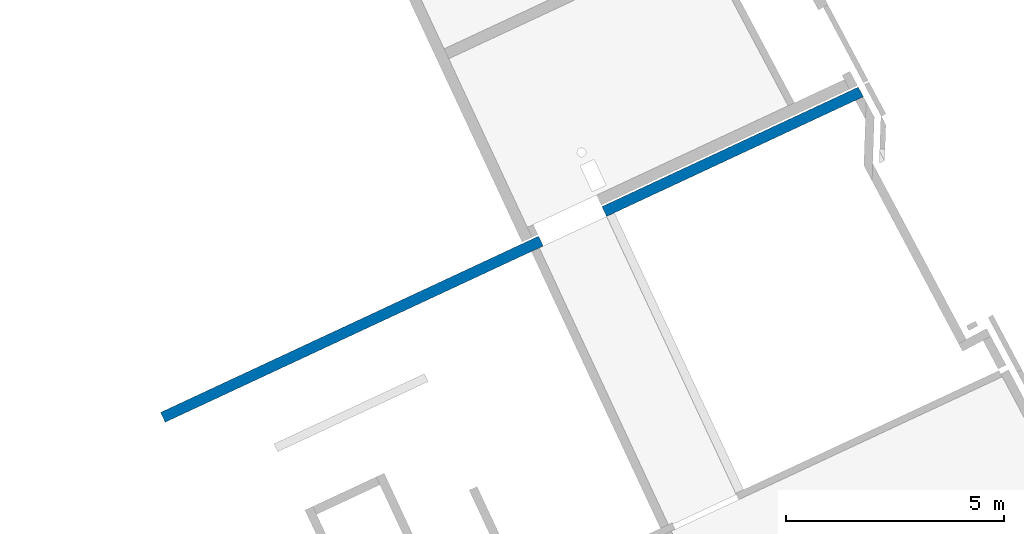
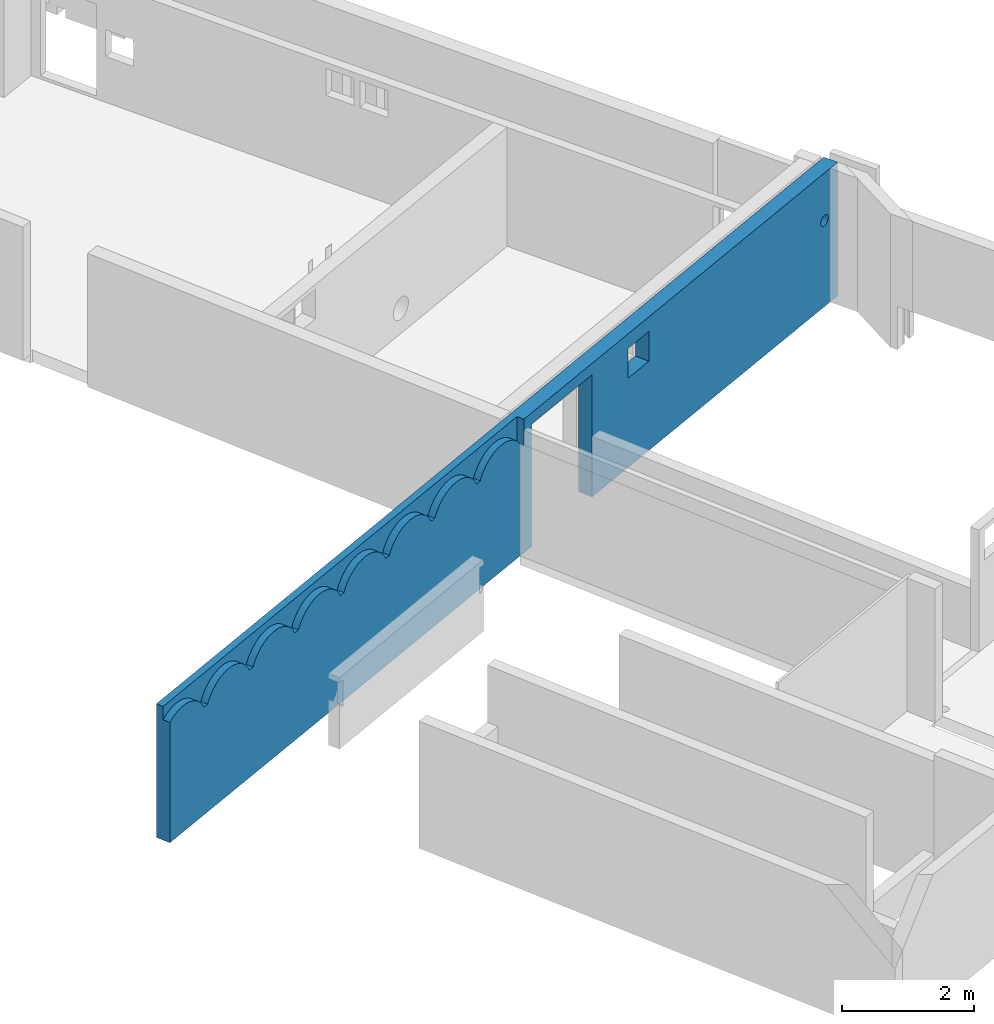
# One storey, part 9 of 13: 1 wall.
"""IFC2X3 building model written with IfcOpenShell, lengths in metres."""

import ifcopenshell
import ifcopenshell.guid

model = None  # the IFC model being written
_history = None  # IfcOwnerHistory: only IFC2X3 demands one
_inside = {}  # id of a spatial element -> (the spatial element, [elements in it])
_under = {}  # id of a project, library or spatial element -> (it, [spatial elements below it])
_declared = {}  # id of a project -> (the project, [libraries it declares])
_typed = {}  # id of a type object -> (the type object, [elements of that type])
_made_of = {}  # id of a material, layer set ... -> (it, [elements and type objects made of it])


def new_model(schema):
    """Start an empty IFC model of exactly this schema.

    Asked for "IFC4X3", IfcOpenShell would pick the latest addendum, in which some entities
    have other attributes; the version numbers below select the first issue.
    IFC2X3 requires an IfcOwnerHistory on every rooted entity: one is made here for all.
    """
    global model, _history
    if schema == "IFC4X3":
        model = ifcopenshell.file(schema_version=(4, 3, 0, 0))
    else:
        model = ifcopenshell.file(schema=schema)
    _inside.clear()
    _under.clear()
    _declared.clear()
    _typed.clear()
    _made_of.clear()
    _history = None
    if model.schema == "IFC2X3":
        org = make("IfcOrganization", Name="unknown")
        user = make(
            "IfcPersonAndOrganization",
            ThePerson=make("IfcPerson", FamilyName="unknown"),
            TheOrganization=org,
        )
        app = make(
            "IfcApplication",
            ApplicationDeveloper=org,
            Version="unknown",
            ApplicationFullName="unknown",
            ApplicationIdentifier="unknown",
        )
        _history = make(
            "IfcOwnerHistory",
            OwningUser=user,
            OwningApplication=app,
            ChangeAction="ADDED",
            CreationDate=0,
        )
    return model


def make(cls, **values):
    """One entity of the class cls with the attributes given. An attribute that is None is left unset."""
    return model.create_entity(
        cls, **{name: value for name, value in values.items() if value is not None}
    )


def entity(cls, *values):
    """Any entity or typed value of the class cls, its attributes in the order of the schema. None: left unset."""
    e = model.create_entity(cls)
    for i, value in enumerate(values):
        if value is not None:
            e[i] = value
    return e


def rooted(cls, **values):
    """An entity with a GlobalId (a new one), such as an element, a storey or a relation."""
    return make(cls, GlobalId=ifcopenshell.guid.new(), OwnerHistory=_history, **values)


def si_unit(unit_type, name, prefix=None):
    """IfcSIUnit, for example si_unit("LENGTHUNIT", "METRE", prefix="MILLI")."""
    return make("IfcSIUnit", UnitType=unit_type, Prefix=prefix, Name=name)


def converted_unit(unit_type, name, factor, base, dimensions=None, offset=None):
    """IfcConversionBasedUnit, such as the inch: factor (a typed value) times the base unit."""
    return make(
        "IfcConversionBasedUnit"
        if offset is None
        else "IfcConversionBasedUnitWithOffset",
        ConversionOffset=offset,
        Dimensions=None
        if dimensions is None
        else entity("IfcDimensionalExponents", *dimensions),
        UnitType=unit_type,
        Name=name,
        ConversionFactor=make(
            "IfcMeasureWithUnit", ValueComponent=factor, UnitComponent=base
        ),
    )


def derived_unit(unit_type, elements):
    """IfcDerivedUnit: a product of units, each with its exponent."""
    return make(
        "IfcDerivedUnit",
        Elements=[
            make("IfcDerivedUnitElement", Unit=unit, Exponent=power)
            for unit, power in elements
        ],
        UnitType=unit_type,
    )


def assignment(units):
    """IfcUnitAssignment: the units of a project."""
    return None if units is None else make("IfcUnitAssignment", Units=units)


def point(xyz):
    """IfcCartesianPoint."""
    return None if xyz is None else make("IfcCartesianPoint", Coordinates=xyz)


def direction(xyz):
    """IfcDirection."""
    return None if xyz is None else make("IfcDirection", DirectionRatios=xyz)


def frame(location, z_axis=None, x_axis=None):
    """IfcAxis2Placement3D, a coordinate frame: its origin and axes. An axis left out is left unset."""
    return make(
        "IfcAxis2Placement3D",
        Location=point(location),
        Axis=direction(z_axis),
        RefDirection=direction(x_axis),
    )


def origin():
    """The frame at (0, 0, 0) with its axes left unset."""
    return frame((0.0, 0.0, 0.0))


def place(relative_to, where):
    """IfcLocalPlacement: puts the frame where relative to a parent placement (None: the world)."""
    return make(
        "IfcLocalPlacement", PlacementRelTo=relative_to, RelativePlacement=where
    )


def context(
    kind, dimensions, precision=None, world=None, true_north=None, identifier=None
):
    """IfcGeometricRepresentationContext, for example the 3D "Model" context."""
    return make(
        "IfcGeometricRepresentationContext",
        ContextIdentifier=identifier,
        ContextType=kind,
        CoordinateSpaceDimension=dimensions,
        Precision=precision,
        WorldCoordinateSystem=world,
        TrueNorth=true_north,
    )


def subcontext(parent, identifier, kind, view, scale=None):
    """IfcGeometricRepresentationSubContext, for example "Body" below "Model"."""
    return make(
        "IfcGeometricRepresentationSubContext",
        ContextIdentifier=identifier,
        ContextType=kind,
        ParentContext=parent,
        TargetScale=scale,
        TargetView=view,
    )


def project(units=None, contexts=None):
    """IfcProject with its units and contexts."""
    return rooted(
        "IfcProject",
        Name="project",
        RepresentationContexts=contexts,
        UnitsInContext=assignment(units),
    )


def spatial(cls, under=None, at=None, **own):
    """A site, building, storey or space (cls), placed at a placement, below another one or the project."""
    s = rooted(cls, ObjectPlacement=at, **own)
    if under is not None:
        _under.setdefault(under.id(), (under, []))[1].append(s)
    return s


def faces_of(points, faces, orient=None, outer=None):
    """IfcFace entities. A face is a list of loops; a loop is a list of indices into points, from 0.

    orient and outer hold one flag for each loop. By default every Orientation is true, the
    first loop of a face is its IfcFaceOuterBound and the others are IfcFaceBound.
    """
    made = []
    for i, loops in enumerate(faces):
        bounds = []
        for j, loop in enumerate(loops):
            is_outer = j == 0 if outer is None else outer[i][j]
            bounds.append(
                make(
                    "IfcFaceOuterBound" if is_outer else "IfcFaceBound",
                    Bound=make("IfcPolyLoop", Polygon=[points[k] for k in loop]),
                    Orientation=True if orient is None else orient[i][j],
                )
            )
        made.append(make("IfcFace", Bounds=bounds))
    return made


def faceted_brep(points, faces, orient=None, outer=None, voids=None):
    """IfcFacetedBrep: a solid bounded by flat faces; with voids (closed shells), ...WithVoids."""
    shared = [point(p) for p in points]
    hull = make("IfcClosedShell", CfsFaces=faces_of(shared, faces, orient, outer))
    if voids is None:
        return make("IfcFacetedBrep", Outer=hull)
    return make(
        "IfcFacetedBrepWithVoids",
        Outer=hull,
        Voids=[
            make(cls, CfsFaces=faces_of(shared, fs, o, b)) for cls, fs, o, b in voids
        ],
    )


def shape(context_of_items, identifier, shape_type, items):
    """IfcShapeRepresentation: the items that make up one representation, for example the "Body"."""
    return make(
        "IfcShapeRepresentation",
        ContextOfItems=context_of_items,
        RepresentationIdentifier=identifier,
        RepresentationType=shape_type,
        Items=items,
    )


def material(Name=None, Category=None):
    """IfcMaterial."""
    return make("IfcMaterial", Name=Name, Category=Category)


def layer(
    of_material, thickness, ventilated=None, Name=None, Category=None, Priority=None
):
    """IfcMaterialLayer: one layer of a wall or slab, of a material (None: an air gap)."""
    return make(
        "IfcMaterialLayer",
        Material=of_material,
        LayerThickness=thickness,
        IsVentilated=ventilated,
        Name=Name,
        Category=Category,
        Priority=Priority,
    )


def layer_set(layers, Name=None):
    """IfcMaterialLayerSet."""
    return make("IfcMaterialLayerSet", MaterialLayers=layers, LayerSetName=Name)


def made_of(thing, what):
    """Note that an element or type object is made of a material, layer set ...; save() writes the relation."""
    if what is not None:
        _made_of.setdefault(what.id(), (what, []))[1].append(thing)
    return thing


def type_object(cls, material=None, **own):
    """A type object (cls), such as IfcWallType, which elements share."""
    return made_of(rooted(cls, **own), material)


def element(
    cls,
    number,
    at=None,
    inside=None,
    cuts=None,
    type_object=None,
    material=None,
    context=None,
    identifier="Body",
    shape_type=None,
    held_by="IfcProductDefinitionShape",
    body=None,
    shapes=None,
    **own,
):
    """One element of the class cls, such as IfcWall. Its Tag is "e" and its number.

    at: its placement. inside: the storey or other place that contains it. cuts: it is an
    opening in that element (IfcRelVoidsElement). A single representation is given by context,
    identifier, shape_type and body (its items); several are given by shapes. held_by: the class
    of the entity that holds the representations. save() writes the other relations.
    """
    e = rooted(cls, Tag="e%d" % number, ObjectPlacement=at, **own)
    if body is not None:
        shapes = [shape(context, identifier, shape_type, body)]
    if shapes is not None:
        e.Representation = make(held_by, Representations=shapes)
    if inside is not None:
        _inside.setdefault(inside.id(), (inside, []))[1].append(e)
    if cuts is not None:
        rooted(
            "IfcRelVoidsElement", RelatingBuildingElement=cuts, RelatedOpeningElement=e
        )
    if type_object is not None:
        _typed.setdefault(type_object.id(), (type_object, []))[1].append(e)
    return made_of(e, material)


def aggregate(whole, parts):
    """IfcRelAggregates: a whole, such as a stair, and the parts it consists of."""
    return rooted("IfcRelAggregates", RelatingObject=whole, RelatedObjects=parts)


def save(model, path):
    """Write the relations noted so far, then the file.

    IfcRelAggregates (storeys below a building ...), IfcRelContainedInSpatialStructure (elements
    in a storey), IfcRelDefinesByType, IfcRelAssociatesMaterial and IfcRelDeclares: one each for
    every whole, place, type object, material and project.
    """
    for whole, parts in _under.values():
        aggregate(whole, parts)
    for where, things in _inside.values():
        rooted(
            "IfcRelContainedInSpatialStructure",
            RelatedElements=things,
            RelatingStructure=where,
        )
    for kind, things in _typed.values():
        rooted("IfcRelDefinesByType", RelatedObjects=things, RelatingType=kind)
    for what, things in _made_of.values():
        rooted("IfcRelAssociatesMaterial", RelatedObjects=things, RelatingMaterial=what)
    for by, libraries in _declared.values():
        rooted("IfcRelDeclares", RelatingContext=by, RelatedDefinitions=libraries)
    model.write(path)


model = new_model("IFC2X3")

# Units and contexts
model_context = context("Model", 3, precision=1e-05, world=origin(), true_north=direction((6.12303176911189e-17, 1.0)))
body_context = subcontext(model_context, "Body", "Model", "MODEL_VIEW")
ifc_project = project(units=[si_unit("LENGTHUNIT", "METRE"), si_unit("AREAUNIT", "SQUARE_METRE"), si_unit("VOLUMEUNIT", "CUBIC_METRE"), converted_unit("PLANEANGLEUNIT", "DEGREE", entity("IfcRatioMeasure", 0.0174532925199433), si_unit("PLANEANGLEUNIT", "RADIAN"), dimensions=[0, 0, 0, 0, 0, 0, 0]), si_unit("MASSUNIT", "GRAM", prefix="KILO"), derived_unit("MASSDENSITYUNIT", [(si_unit("MASSUNIT", "GRAM", prefix="KILO"), 1), (si_unit("LENGTHUNIT", "METRE"), -3)]), si_unit("TIMEUNIT", "SECOND"), si_unit("FREQUENCYUNIT", "HERTZ"), si_unit("THERMODYNAMICTEMPERATUREUNIT", "DEGREE_CELSIUS"), derived_unit("THERMALTRANSMITTANCEUNIT", [(si_unit("MASSUNIT", "GRAM", prefix="KILO"), 1), (si_unit("THERMODYNAMICTEMPERATUREUNIT", "KELVIN"), -1), (si_unit("TIMEUNIT", "SECOND"), -3)]), derived_unit("VOLUMETRICFLOWRATEUNIT", [(si_unit("LENGTHUNIT", "METRE"), 3), (si_unit("TIMEUNIT", "SECOND"), -1)]), si_unit("ELECTRICCURRENTUNIT", "AMPERE"), si_unit("ELECTRICVOLTAGEUNIT", "VOLT"), si_unit("POWERUNIT", "WATT"), si_unit("FORCEUNIT", "NEWTON", prefix="KILO"), si_unit("ILLUMINANCEUNIT", "LUX"), si_unit("LUMINOUSFLUXUNIT", "LUMEN"), si_unit("LUMINOUSINTENSITYUNIT", "CANDELA"), derived_unit("USERDEFINED", [(si_unit("MASSUNIT", "GRAM", prefix="KILO"), -1), (si_unit("LENGTHUNIT", "METRE"), -2), (si_unit("TIMEUNIT", "SECOND"), 3), (si_unit("LUMINOUSFLUXUNIT", "LUMEN"), 1)]), derived_unit("LINEARVELOCITYUNIT", [(si_unit("LENGTHUNIT", "METRE"), 1), (si_unit("TIMEUNIT", "SECOND"), -1)]), si_unit("PRESSUREUNIT", "PASCAL"), derived_unit("USERDEFINED", [(si_unit("LENGTHUNIT", "METRE"), -2), (si_unit("MASSUNIT", "GRAM", prefix="KILO"), 1), (si_unit("TIMEUNIT", "SECOND"), -2)])], contexts=[model_context])

# Site, building, storey
site_placement = place(None, frame((5.36960000000003, 43.3158000000006, 0.0), z_axis=(0.0, 0.0, 1.0), x_axis=(-0.422618261740703, 0.906307787036648, 0.0)))
site = spatial("IfcSite", under=ifc_project, at=site_placement, CompositionType="ELEMENT")
building_placement = place(site_placement, origin())
building = spatial("IfcBuilding", under=site, at=building_placement, CompositionType="ELEMENT")
storey_placement = place(building_placement, frame((0.0, 0.0, 2.56)))
storey = spatial("IfcBuildingStorey", under=building, at=storey_placement, CompositionType="ELEMENT", Elevation=2.56)

# Wall
ifc_material = material(Name="C30/37 XC1")
ifc_layer = layer(ifc_material, 0.25)
ifc_layer_set = layer_set([ifc_layer])
wall_type = type_object("IfcWallType", PredefinedType="NOTDEFINED", material=ifc_layer_set)
wall_placement = place(storey_placement, frame((20.2006620018757, 18.9825258490251, 0.0), z_axis=(0.0, 0.0, 1.0), x_axis=(0.0, -1.0, 0.0)))
element("IfcWall", 1, at=wall_placement, inside=storey, type_object=wall_type, Name="XS1", context=body_context, shape_type="Brep", body=[
    faceted_brep([(0.0, 0.125000000000004, 0.0), (9.55000000000041, 0.125000000000001, 0.0), (9.55000000000041, -0.124999999999998, 0.0), (0.0, -0.124999999999996, 0.0), (11.1500000000004, 0.125000000000005, 0.0), (17.6252183231475, 0.125000000000004, 0.0), (17.6382664720619, -0.124999999999995, 0.0), (11.1500000000004, -0.124999999999994, 0.0), (0.997026073255658, -0.124999999999997, 1.99000000000003), (0.902973926748225, -0.124999999999997, 1.99000000000002), (1.09320268034032, -0.124999999999996, 2.13128922588686), (1.0401959652435, -0.124999999999996, 2.06399261157949), (0.0, -0.124999999999996, 2.22473306581171), (2.1029739267472, -0.124999999999997, 1.99000000000002), (0.803508198615784, -0.124999999999998, 2.13488684825282), (0.858428575975522, -0.124999999999998, 2.06600468446964), (2.19702607325565, -0.124999999999996, 1.99000000000004), (2.29320268034031, -0.124999999999995, 2.13128922588687), (2.24019596524349, -0.124999999999996, 2.0639926115795), (2.05980403475933, -0.124999999999997, 2.06399261157947), (2.00679731966251, -0.124999999999997, 2.13128922588684), (3.30297392674719, -0.124999999999996, 1.99000000000002), (2.99981137346517, -0.124999999999998, 2.28081136055136), (1.71926794870447, -0.124999999999995, 2.30998845551312), (3.14497656206349, -0.124999999999997, 2.19059133438625), (3.20679731966251, -0.124999999999997, 2.13128922588685), (0.73933350346117, -0.124999999999994, 2.19524087743565), (0.667214043514616, -0.124999999999995, 2.2458351837735), (0.330505011380656, -0.124999999999998, 2.33336455871782), (1.15502343793934, -0.124999999999995, 2.19059133438626), (1.94497656206349, -0.124999999999998, 2.19059133438624), (2.42446538781674, -0.124999999999998, 2.24075468495034), (2.35502343793934, -0.124999999999995, 2.19059133438626), (1.87553461218609, -0.124999999999998, 2.24075468495032), (1.22446538781675, -0.124999999999995, 2.24075468495034), (3.25980403475933, -0.124999999999996, 2.06399261157947), (3.07553461218608, -0.124999999999998, 2.24075468495033), (4.59702607325537, -0.124999999999994, 1.99000000000004), (4.50297392674635, -0.124999999999995, 1.99000000000003), (3.39702607325481, -0.124999999999995, 1.99000000000004), (4.19981137346433, -0.124999999999997, 2.28081136055136), (4.45980403475848, -0.124999999999995, 2.06399261157947), (4.40679731966166, -0.124999999999996, 2.13128922588685), (5.70297392674691, -0.124999999999999, 1.99000000000003), (4.69320268034003, -0.124999999999998, 2.13128922588688), (4.64019596524321, -0.124999999999998, 2.0639926115795), (5.65980403475904, -0.124999999999995, 2.06399261157948), (5.60679731966222, -0.124999999999995, 2.13128922588685), (5.79702607325592, -0.124999999999998, 1.99000000000005), (5.89320268034058, -0.124999999999997, 2.13128922588688), (5.84019596524376, -0.124999999999997, 2.06399261157951), (5.4755346121858, -0.124999999999996, 2.24075468495034), (3.6244653878159, -0.124999999999998, 2.24075468495035), (3.55502343793849, -0.124999999999998, 2.19059133438627), (4.34497656206265, -0.124999999999996, 2.19059133438625), (3.49320268033947, -0.124999999999994, 2.13128922588687), (3.44019596524265, -0.124999999999995, 2.0639926115795), (4.27553461218524, -0.124999999999997, 2.24075468495033), (5.5449765620632, -0.124999999999995, 2.19059133438625), (4.75502343793905, -0.124999999999997, 2.19059133438627), (4.82446538781646, -0.124999999999997, 2.24075468495035), (5.9550234379396, -0.124999999999997, 2.19059133438627), (5.39981137346488, -0.124999999999997, 2.28081136055137), (0.0759203321441607, -0.124999999999995, 2.26942202981751), (0.157433551815444, -0.124999999999995, 2.30283752555842), (0.418531543814971, -0.124999999999997, 2.32985315951233), (0.505159617109286, -0.124999999999996, 2.31383513047927), (0.588621493166093, -0.124999999999996, 2.2856373365608), (1.30018862653767, -0.124999999999994, 2.28081136055137), (1.63545844765585, -0.124999999999996, 2.32772298895983), (2.50018862653766, -0.124999999999998, 2.28081136055137), (1.79981137346517, -0.124999999999995, 2.28081136055136), (0.242876294952018, -0.124999999999998, 2.32429767425518), (1.55000000000142, -0.124999999999997, 2.33367276770245), (2.58073205129837, -0.124999999999997, 2.30998845551314), (1.38073205129837, -0.124999999999998, 2.30998845551313), (1.46454155234699, -0.124999999999997, 2.32772298895984), (2.66454155234699, -0.124999999999997, 2.32772298895984), (3.70018862653682, -0.124999999999997, 2.28081136055137), (4.035458447655, -0.124999999999994, 2.32772298895984), (4.11926794870362, -0.124999999999998, 2.30998845551313), (2.83545844765585, -0.124999999999995, 2.32772298895984), (2.91926794870447, -0.124999999999995, 2.30998845551313), (5.31926794870418, -0.124999999999997, 2.30998845551313), (5.23545844765556, -0.124999999999998, 2.32772298895984), (4.90018862653738, -0.124999999999996, 2.28081136055138), (4.98073205129808, -0.124999999999996, 2.30998845551314), (5.15000000000113, -0.124999999999999, 2.33367276770246), (2.75000000000142, -0.124999999999996, 2.33367276770246), (3.78073205129752, -0.124999999999996, 2.30998845551314), (5.0645415523467, -0.124999999999995, 2.32772298895985), (3.86454155234614, -0.124999999999996, 2.32772298895985), (3.95000000000057, -0.124999999999995, 2.33367276770246), (9.2598040347599, -0.124999999999996, 2.06399261157949), (8.19702607325622, -0.124999999999996, 1.99000000000006), (9.30297392674776, -0.124999999999996, 1.99000000000004), (9.35000000000049, -0.124999999999996, 1.99000000000006), (8.10297392674802, -0.124999999999997, 1.99000000000004), (17.1934074173715, -0.124999999999994, 1.56411809578654), (17.1900000000004, -0.124999999999994, 1.59000000029679), (12.6488855028243, -0.124999999999996, 1.65), (12.0988855028243, -0.124999999999996, 1.65), (17.1934074173715, -0.124999999999994, 1.61588190480704), (11.1500000000004, -0.124999999999994, 2.26), (17.203397459622, -0.124999999999994, 1.54000000029679), (6.90297392674746, -0.124999999999998, 1.99000000000004), (6.99702607325648, -0.124999999999997, 1.99000000000005), (7.09320268034114, -0.124999999999996, 2.13128922588688), (7.04019596524432, -0.124999999999997, 2.06399261157951), (8.00679731966333, -0.124999999999998, 2.13128922588686), (7.94497656206431, -0.124999999999998, 2.19059133438626), (8.05980403476015, -0.124999999999997, 2.06399261157949), (6.85980403475959, -0.124999999999998, 2.06399261157948), (6.80679731966277, -0.124999999999998, 2.13128922588686), (9.20679731966308, -0.124999999999997, 2.13128922588687), (8.24019596524406, -0.124999999999996, 2.06399261157951), (9.14497656206406, -0.124999999999997, 2.19059133438626), (9.07553461218665, -0.124999999999998, 2.24075468495035), (8.29320268034088, -0.124999999999995, 2.13128922588689), (12.6488855028243, -0.124999999999996, 2.2), (17.2900000000004, -0.124999999999998, 1.49000000029679), (17.2641180954902, -0.124999999999998, 1.49340741766788), (17.2192893218818, -0.124999999999999, 1.51928932217814), (17.2400000000004, -0.124999999999998, 1.50339745991835), (17.3158819045107, -0.124999999999998, 1.49340741766788), (17.3400000000004, -0.124999999999998, 1.50339745991835), (17.3607106781191, -0.124999999999997, 1.51928932217813), (17.3766025403789, -0.124999999999997, 1.54000000029679), (17.3865925826293, -0.124999999999997, 1.56411809578654), (17.3900000000004, -0.124999999999997, 1.59000000029679), (17.203397459622, -0.124999999999994, 1.64000000029679), (17.437994250619, -0.124999999999997, 2.47), (17.2400000000004, -0.124999999999998, 1.67660254067523), (17.2641180954902, -0.124999999999998, 1.6865925829257), (17.2192893218818, -0.124999999999999, 1.66071067841544), (17.6382664720619, -0.124999999999995, 2.47), (17.3865925826293, -0.124999999999997, 1.61588190480704), (17.3766025403789, -0.124999999999997, 1.64000000029679), (17.3400000000004, -0.124999999999998, 1.67660254067523), (17.3607106781191, -0.124999999999997, 1.66071067841544), (17.3158819045107, -0.124999999999998, 1.6865925829257), (17.2900000000004, -0.124999999999998, 1.69000000029679), (6.67553461218635, -0.124999999999995, 2.24075468495034), (6.59981137346543, -0.124999999999996, 2.28081136055137), (6.74497656206376, -0.124999999999995, 2.19059133438626), (6.02446538781701, -0.124999999999996, 2.24075468495035), (6.51926794870473, -0.124999999999996, 2.30998845551314), (6.43545844765611, -0.124999999999997, 2.32772298895985), (7.15502343794016, -0.124999999999996, 2.19059133438628), (7.22446538781757, -0.124999999999995, 2.24075468495036), (7.30018862653849, -0.124999999999995, 2.28081136055139), (6.10018862653793, -0.124999999999995, 2.28081136055138), (6.18073205129863, -0.124999999999995, 2.30998845551315), (6.26454155234725, -0.124999999999998, 2.32772298895985), (6.35000000000168, -0.124999999999998, 2.33367276770247), (7.46454155234781, -0.124999999999998, 2.32772298895986), (7.55000000000224, -0.124999999999997, 2.33367276770247), (7.38073205129919, -0.124999999999998, 2.30998845551315), (7.63545844765667, -0.124999999999996, 2.32772298895985), (7.71926794870529, -0.124999999999996, 2.30998845551314), (7.87553461218691, -0.124999999999994, 2.24075468495034), (8.35502343793991, -0.124999999999995, 2.19059133438628), (8.91926794870504, -0.124999999999995, 2.30998845551315), (8.42446538781731, -0.124999999999994, 2.24075468495036), (8.99981137346574, -0.124999999999998, 2.28081136055138), (7.79981137346599, -0.124999999999995, 2.28081136055137), (12.0988855028243, -0.124999999999996, 2.2), (9.55000000000041, -0.124999999999998, 2.26), (9.3500000000005, -0.124999999999996, 2.26), (9.35000000000049, -0.124999999999996, 2.47), (8.58073205129893, -0.124999999999997, 2.30998845551315), (8.75000000000198, -0.124999999999996, 2.33367276770248), (8.66454155234756, -0.124999999999997, 2.32772298895986), (8.50018862653823, -0.124999999999998, 2.28081136055139), (8.83545844765641, -0.124999999999995, 2.32772298895986), (17.3607106781191, 0.125000000000002, 1.51928932217813), (17.3766025403789, 0.125000000000002, 1.54000000029679), (17.3400000000004, 0.125000000000002, 1.50339745991835), (17.3865925826293, 0.125000000000002, 1.56411809578654), (17.3900000000004, 0.125000000000002, 1.59000000029679), (17.3158819045107, 0.125000000000002, 1.49340741766788), (17.2900000000004, 0.125000000000002, 1.49000000029679), (17.2641180954902, 0.125000000000001, 1.49340741766788), (17.2400000000004, 0.125000000000001, 1.50339745991835), (17.2192893218818, 0.125000000000001, 1.51928932217814), (17.6252183231475, 0.125000000000004, 2.47), (17.203397459622, 0.125000000000005, 1.54000000029679), (12.6488855028243, 0.125000000000004, 1.65), (12.0988855028243, 0.125000000000004, 1.65), (11.1500000000004, 0.125000000000005, 2.26), (12.0988855028243, 0.125000000000004, 2.2), (12.6488855028243, 0.125000000000004, 2.2), (9.02999999999992, 0.125000000000001, 2.47), (9.55000000000041, 0.125000000000001, 2.26), (7.22999999999992, 0.125000000000004, 2.47), (0.0, 0.125000000000004, 2.47), (17.3865925826293, 0.125000000000002, 1.61588190480704), (17.3766025403789, 0.125000000000002, 1.64000000029679), (17.3607106781191, 0.125000000000002, 1.66071067841544), (17.3400000000004, 0.125000000000002, 1.67660254067523), (17.3158819045107, 0.125000000000002, 1.6865925829257), (17.2900000000004, 0.125000000000002, 1.69000000029679), (17.2641180954902, 0.125000000000001, 1.6865925829257), (17.2400000000004, 0.125000000000001, 1.67660254067523), (17.2192893218818, 0.125000000000001, 1.66071067841544), (17.203397459622, 0.125000000000005, 1.64000000029679), (17.1934074173715, 0.125000000000005, 1.61588190480704), (17.1900000000004, 0.125000000000005, 1.59000000029679), (17.1934074173715, 0.125000000000005, 1.56411809578654), (9.35000000000049, 0.0, 2.47), (0.0, 0.0, 2.47), (0.0, 0.0, 2.22473306581171), (9.35000000000049, 0.0, 1.99000000000006), (8.750000000002, 0.0, 2.33367276770248), (8.83545844765643, 0.0, 2.32772298895986), (8.91926794870505, 0.0, 2.30998845551315), (8.99981137346576, 0.0, 2.28081136055138), (9.07553461218667, 0.0, 2.24075468495035), (9.14497656206408, 0.0, 2.19059133438627), (9.2067973196631, 0.0, 2.13128922588688), (9.25980403475992, 0.0, 2.0639926115795), (9.30297392674779, 0.0, 1.99000000000006), (0.0698594410117893, 0.0, 2.26637349975143), (0.144590362236288, 0.0, 2.29845905103494), (0.222893272112677, 0.0, 2.32043193606506), (0.303406621987858, 0.0, 2.33191014134613), (0.384730447973248, 0.0, 2.33269405256331), (0.46545068368209, 0.0, 2.32276992253606), (0.54416371814875, 0.0, 2.30231011480544), (0.619500773515448, 0.0, 2.27167011849557), (0.690151680157912, 0.0, 2.23138238591999), (0.754887637293837, 0.0, 2.18214709935334), (0.812582564600649, 0.0, 2.12482002650976), (0.862232114802976, 0.0, 2.06039850968235), (0.902973926748255, 0.0, 1.99000000000003), (0.997026073255649, 0.0, 1.99000000000003), (1.04019596524352, 0.0, 2.06399261157948), (1.09320268034034, 0.0, 2.13128922588685), (1.15502343793936, 0.0, 2.19059133438625), (1.22446538781677, 0.0, 2.24075468495033), (1.30018862653769, 0.0, 2.28081136055136), (1.38073205129839, 0.0, 2.30998845551313), (1.46454155234701, 0.0, 2.32772298895984), (1.55000000000144, 0.0, 2.33367276770245), (1.63545844765587, 0.0, 2.32772298895984), (1.71926794870449, 0.0, 2.30998845551313), (1.79981137346519, 0.0, 2.28081136055136), (1.87553461218611, 0.0, 2.24075468495033), (1.94497656206351, 0.0, 2.19059133438625), (2.00679731966253, 0.0, 2.13128922588685), (2.05980403475935, 0.0, 2.06399261157948), (2.10297392674723, 0.0, 1.99000000000004), (2.19702607325565, 0.0, 1.99000000000004), (2.24019596524351, 0.0, 2.06399261157948), (2.29320268034034, 0.0, 2.13128922588686), (2.35502343793936, 0.0, 2.19059133438625), (2.42446538781676, 0.0, 2.24075468495034), (2.50018862653768, 0.0, 2.28081136055137), (2.58073205129838, 0.0, 2.30998845551313), (2.664541552347, 0.0, 2.32772298895984), (2.75000000000143, 0.0, 2.33367276770246), (2.83545844765586, 0.0, 2.32772298895984), (2.91926794870448, 0.0, 2.30998845551313), (2.99981137346519, 0.0, 2.28081136055137), (3.07553461218611, 0.0, 2.24075468495034), (3.14497656206351, 0.0, 2.19059133438625), (3.20679731966253, 0.0, 2.13128922588686), (3.25980403475935, 0.0, 2.06399261157948), (3.30297392674722, 0.0, 1.99000000000004), (3.3970260732548, 0.0, 1.99000000000004), (3.44019596524267, 0.0, 2.06399261157949), (3.49320268033949, 0.0, 2.13128922588686), (3.55502343793851, 0.0, 2.19059133438626), (3.62446538781592, 0.0, 2.24075468495034), (3.70018862653684, 0.0, 2.28081136055137), (3.78073205129754, 0.0, 2.30998845551314), (3.86454155234616, 0.0, 2.32772298895984), (3.95000000000059, 0.0, 2.33367276770246), (4.03545844765502, 0.0, 2.32772298895984), (4.11926794870364, 0.0, 2.30998845551313), (4.19981137346434, 0.0, 2.28081136055137), (4.27553461218526, 0.0, 2.24075468495034), (4.34497656206266, 0.0, 2.19059133438626), (4.40679731966169, 0.0, 2.13128922588686), (4.45980403475851, 0.0, 2.06399261157949), (4.50297392674638, 0.0, 1.99000000000004), (4.59702607325536, 0.0, 1.99000000000004), (4.64019596524323, 0.0, 2.06399261157949), (4.69320268034005, 0.0, 2.13128922588687), (4.75502343793907, 0.0, 2.19059133438626), (4.82446538781648, 0.0, 2.24075468495034), (4.90018862653739, 0.0, 2.28081136055137), (4.9807320512981, 0.0, 2.30998845551314), (5.06454155234672, 0.0, 2.32772298895985), (5.15000000000115, 0.0, 2.33367276770246), (5.23545844765558, 0.0, 2.32772298895985), (5.3192679487042, 0.0, 2.30998845551314), (5.3998113734649, 0.0, 2.28081136055137), (5.47553461218582, 0.0, 2.24075468495034), (5.54497656206322, 0.0, 2.19059133438626), (5.60679731966224, 0.0, 2.13128922588687), (5.65980403475906, 0.0, 2.06399261157949), (5.70297392674694, 0.0, 1.99000000000005), (5.79702607325591, 0.0, 1.99000000000005), (5.84019596524378, 0.0, 2.06399261157949), (5.8932026803406, 0.0, 2.13128922588687), (5.95502343793962, 0.0, 2.19059133438627), (6.02446538781703, 0.0, 2.24075468495035), (6.10018862653794, 0.0, 2.28081136055138), (6.18073205129865, 0.0, 2.30998845551314), (6.26454155234727, 0.0, 2.32772298895985), (6.3500000000017, 0.0, 2.33367276770247), (6.43545844765613, 0.0, 2.32772298895985), (6.51926794870475, 0.0, 2.30998845551314), (6.59981137346545, 0.0, 2.28081136055138), (6.67553461218637, 0.0, 2.24075468495035), (6.74497656206377, 0.0, 2.19059133438627), (6.80679731966279, 0.0, 2.13128922588687), (6.85980403475961, 0.0, 2.0639926115795), (6.90297392674749, 0.0, 1.99000000000005), (6.99702607325647, 0.0, 1.99000000000005), (7.04019596524434, 0.0, 2.0639926115795), (7.09320268034116, 0.0, 2.13128922588687), (7.15502343794018, 0.0, 2.19059133438627), (7.22446538781759, 0.0, 2.24075468495035), (7.30018862653851, 0.0, 2.28081136055138), (7.38073205129921, 0.0, 2.30998845551315), (7.46454155234783, 0.0, 2.32772298895985), (7.55000000000226, 0.0, 2.33367276770247), (7.63545844765669, 0.0, 2.32772298895985), (7.71926794870531, 0.0, 2.30998845551315), (7.79981137346601, 0.0, 2.28081136055138), (7.87553461218693, 0.0, 2.24075468495035), (7.94497656206433, 0.0, 2.19059133438627), (8.00679731966335, 0.0, 2.13128922588687), (8.05980403476017, 0.0, 2.0639926115795), (8.10297392674805, 0.0, 1.99000000000006), (8.19702607325621, 0.0, 1.99000000000006), (8.24019596524408, 0.0, 2.0639926115795), (8.2932026803409, 0.0, 2.13128922588688), (8.35502343793993, 0.0, 2.19059133438627), (8.42446538781733, 0.0, 2.24075468495035), (8.50018862653825, 0.0, 2.28081136055138), (8.58073205129895, 0.0, 2.30998845551315), (8.66454155234757, 0.0, 2.32772298895986)], [[[0, 1, 2, 3]], [[4, 5, 6, 7]], [[3, 8, 9]], [[10, 11, 8]], [[3, 9, 12]], [[8, 3, 13]], [[14, 9, 15]], [[16, 13, 3]], [[17, 18, 16]], [[13, 19, 20]], [[16, 21, 22]], [[23, 8, 13]], [[16, 3, 21]], [[24, 21, 25]], [[26, 27, 9]], [[28, 12, 9]], [[8, 29, 10]], [[26, 9, 14]], [[30, 13, 20]], [[16, 31, 32]], [[17, 16, 32]], [[13, 30, 33]], [[34, 29, 8]], [[25, 21, 35]], [[36, 21, 24]], [[37, 38, 3]], [[38, 39, 3]], [[39, 38, 40]], [[41, 42, 38]], [[39, 21, 3]], [[2, 43, 37]], [[37, 44, 45]], [[46, 47, 43]], [[48, 49, 50]], [[43, 51, 37]], [[43, 2, 48]], [[39, 52, 53]], [[38, 42, 54]], [[39, 55, 56]], [[39, 53, 55]], [[38, 54, 57]], [[47, 58, 43]], [[58, 51, 43]], [[37, 59, 44]], [[59, 37, 60]], [[48, 61, 49]], [[2, 37, 3]], [[37, 51, 62]], [[63, 12, 64]], [[65, 9, 66]], [[67, 66, 9]], [[9, 27, 67]], [[8, 68, 34]], [[69, 8, 23]], [[16, 70, 31]], [[13, 71, 23]], [[13, 33, 71]], [[72, 64, 12]], [[28, 72, 12]], [[9, 65, 28]], [[8, 69, 73]], [[70, 16, 74]], [[75, 68, 8]], [[75, 8, 76]], [[73, 76, 8]], [[77, 74, 16]], [[78, 52, 39]], [[79, 39, 80]], [[40, 80, 39]], [[81, 16, 82]], [[40, 38, 57]], [[83, 37, 62]], [[37, 83, 84]], [[37, 85, 60]], [[85, 37, 86]], [[37, 84, 87]], [[21, 36, 22]], [[88, 77, 16]], [[89, 78, 39]], [[81, 88, 16]], [[87, 90, 37]], [[90, 86, 37]], [[91, 89, 39]], [[92, 91, 39]], [[92, 39, 79]], [[82, 16, 22]], [[93, 94, 95]], [[95, 94, 2]], [[96, 95, 2]], [[2, 94, 97]], [[98, 99, 100]], [[100, 101, 7]], [[100, 99, 102]], [[7, 101, 103]], [[98, 100, 104]], [[100, 7, 6]], [[105, 2, 106]], [[106, 107, 108]], [[109, 110, 106]], [[106, 111, 109]], [[105, 112, 113]], [[94, 93, 114]], [[115, 94, 116]], [[117, 118, 115]], [[97, 111, 106]], [[2, 97, 106]], [[94, 114, 116]], [[119, 100, 102]], [[48, 105, 113]], [[120, 121, 6]], [[122, 104, 6]], [[123, 122, 6]], [[121, 123, 6]], [[124, 6, 125]], [[6, 124, 120]], [[125, 6, 126]], [[127, 126, 6]], [[128, 127, 6]], [[6, 129, 128]], [[104, 100, 6]], [[119, 102, 130]], [[131, 132, 133]], [[131, 134, 132]], [[131, 130, 134]], [[135, 136, 129]], [[137, 136, 135]], [[138, 139, 135]], [[140, 138, 131]], [[137, 135, 139]], [[141, 140, 131]], [[129, 6, 135]], [[141, 131, 133]], [[142, 143, 48]], [[144, 142, 48]], [[61, 48, 145]], [[48, 143, 146]], [[48, 146, 147]], [[106, 148, 107]], [[106, 149, 148]], [[150, 149, 106]], [[113, 144, 48]], [[48, 151, 145]], [[151, 48, 152]], [[153, 152, 48]], [[153, 48, 154]], [[154, 48, 147]], [[155, 106, 156]], [[157, 150, 106]], [[155, 157, 106]], [[156, 106, 158]], [[159, 158, 106]], [[160, 106, 110]], [[161, 162, 163]], [[118, 164, 161]], [[117, 164, 118]], [[159, 106, 165]], [[117, 115, 116]], [[166, 103, 101]], [[166, 119, 103]], [[167, 96, 2]], [[96, 167, 168]], [[167, 103, 169]], [[168, 167, 169]], [[119, 169, 103]], [[170, 171, 172]], [[171, 170, 173]], [[173, 174, 171]], [[163, 174, 173]], [[163, 162, 174]], [[119, 131, 169]], [[130, 131, 119]], [[161, 164, 162]], [[138, 135, 131]], [[106, 160, 165]], [[105, 48, 2]], [[5, 175, 176]], [[175, 5, 177]], [[176, 178, 5]], [[5, 178, 179]], [[180, 177, 5]], [[181, 180, 5]], [[182, 181, 5]], [[182, 5, 183]], [[5, 184, 183]], [[179, 185, 5]], [[186, 184, 5]], [[186, 5, 187]], [[5, 4, 187]], [[188, 187, 4]], [[189, 188, 4]], [[188, 189, 190]], [[191, 190, 189]], [[189, 192, 191]], [[189, 193, 192]], [[1, 192, 193]], [[192, 1, 194]], [[194, 1, 0]], [[0, 195, 194]], [[191, 192, 185]], [[179, 196, 185]], [[197, 185, 196]], [[185, 197, 198]], [[185, 198, 199]], [[199, 200, 185]], [[200, 201, 185]], [[201, 202, 185]], [[203, 185, 202]], [[185, 203, 204]], [[185, 205, 191]], [[205, 185, 204]], [[191, 205, 206]], [[206, 207, 187]], [[191, 206, 187]], [[208, 187, 207]], [[186, 187, 208]], [[209, 169, 131, 135, 185, 192, 194, 195, 210]], [[3, 12, 211, 210, 195, 0]], [[103, 189, 4, 7]], [[167, 2, 1, 193]], [[167, 193, 189, 103]], [[135, 6, 5, 185]], [[168, 169, 209, 212, 96]], [[213, 214, 215, 216, 217, 218, 219, 220, 221, 212, 209, 210, 211, 222, 223, 224, 225, 226, 227, 228, 229, 230, 231, 232, 233, 234, 235, 236, 237, 238, 239, 240, 241, 242, 243, 244, 245, 246, 247, 248, 249, 250, 251, 252, 253, 254, 255, 256, 257, 258, 259, 260, 261, 262, 263, 264, 265, 266, 267, 268, 269, 270, 271, 272, 273, 274, 275, 276, 277, 278, 279, 280, 281, 282, 283, 284, 285, 286, 287, 288, 289, 290, 291, 292, 293, 294, 295, 296, 297, 298, 299, 300, 301, 302, 303, 304, 305, 306, 307, 308, 309, 310, 311, 312, 313, 314, 315, 316, 317, 318, 319, 320, 321, 322, 323, 324, 325, 326, 327, 328, 329, 330, 331, 332, 333, 334, 335, 336, 337, 338, 339, 340, 341, 342, 343, 344]], [[222, 12, 63]], [[64, 223, 63]], [[225, 72, 28]], [[64, 72, 224]], [[226, 28, 65]], [[222, 211, 12]], [[223, 222, 63]], [[225, 224, 72]], [[227, 226, 65]], [[225, 28, 226]], [[223, 64, 224]], [[65, 66, 227]], [[228, 66, 67]], [[27, 229, 67]], [[231, 26, 14]], [[14, 15, 232]], [[26, 230, 27]], [[233, 15, 9]], [[229, 228, 67]], [[230, 229, 27]], [[232, 231, 14]], [[234, 233, 9]], [[232, 15, 233]], [[230, 26, 231]], [[66, 228, 227]], [[235, 234, 9, 8]], [[252, 251, 13, 16]], [[269, 268, 21, 39]], [[286, 285, 38, 37]], [[303, 302, 43, 48]], [[320, 319, 105, 106]], [[337, 336, 97, 94]], [[212, 221, 95, 96]], [[238, 237, 10, 29]], [[10, 237, 236, 11]], [[34, 239, 238, 29]], [[75, 241, 240, 68]], [[241, 75, 76, 242]], [[240, 239, 34, 68]], [[73, 243, 242, 76]], [[11, 236, 235, 8]], [[244, 69, 23, 245]], [[245, 23, 71, 246]], [[33, 247, 246, 71]], [[248, 30, 20, 249]], [[20, 19, 250, 249]], [[30, 248, 247, 33]], [[250, 19, 13, 251]], [[244, 243, 73, 69]], [[255, 254, 17, 32]], [[17, 254, 253, 18]], [[31, 256, 255, 32]], [[74, 258, 257, 70]], [[258, 74, 77, 259]], [[257, 256, 31, 70]], [[88, 260, 259, 77]], [[18, 253, 252, 16]], [[261, 81, 82, 262]], [[262, 82, 22, 263]], [[36, 264, 263, 22]], [[265, 24, 25, 266]], [[25, 35, 267, 266]], [[24, 265, 264, 36]], [[267, 35, 21, 268]], [[261, 260, 88, 81]], [[272, 271, 55, 53]], [[55, 271, 270, 56]], [[52, 273, 272, 53]], [[89, 275, 274, 78]], [[275, 89, 91, 276]], [[274, 273, 52, 78]], [[92, 277, 276, 91]], [[56, 270, 269, 39]], [[278, 79, 80, 279]], [[279, 80, 40, 280]], [[57, 281, 280, 40]], [[282, 54, 42, 283]], [[42, 41, 284, 283]], [[54, 282, 281, 57]], [[284, 41, 38, 285]], [[278, 277, 92, 79]], [[289, 288, 44, 59]], [[44, 288, 287, 45]], [[60, 290, 289, 59]], [[86, 292, 291, 85]], [[292, 86, 90, 293]], [[291, 290, 60, 85]], [[87, 294, 293, 90]], [[45, 287, 286, 37]], [[295, 84, 83, 296]], [[296, 83, 62, 297]], [[51, 298, 297, 62]], [[299, 58, 47, 300]], [[47, 46, 301, 300]], [[58, 299, 298, 51]], [[301, 46, 43, 302]], [[295, 294, 87, 84]], [[306, 305, 49, 61]], [[49, 305, 304, 50]], [[145, 307, 306, 61]], [[152, 309, 308, 151]], [[309, 152, 153, 310]], [[308, 307, 145, 151]], [[154, 311, 310, 153]], [[50, 304, 303, 48]], [[312, 147, 146, 313]], [[313, 146, 143, 314]], [[142, 315, 314, 143]], [[316, 144, 113, 317]], [[113, 112, 318, 317]], [[144, 316, 315, 142]], [[318, 112, 105, 319]], [[312, 311, 154, 147]], [[323, 322, 107, 148]], [[107, 322, 321, 108]], [[149, 324, 323, 148]], [[157, 326, 325, 150]], [[326, 157, 155, 327]], [[325, 324, 149, 150]], [[156, 328, 327, 155]], [[108, 321, 320, 106]], [[329, 158, 159, 330]], [[330, 159, 165, 331]], [[160, 332, 331, 165]], [[333, 110, 109, 334]], [[109, 111, 335, 334]], [[110, 333, 332, 160]], [[335, 111, 97, 336]], [[329, 328, 156, 158]], [[340, 339, 118, 161]], [[118, 339, 338, 115]], [[163, 341, 340, 161]], [[170, 343, 342, 173]], [[343, 170, 172, 344]], [[342, 341, 163, 173]], [[171, 213, 344, 172]], [[115, 338, 337, 94]], [[214, 174, 162, 215]], [[215, 162, 164, 216]], [[117, 217, 216, 164]], [[218, 116, 114, 219]], [[114, 93, 220, 219]], [[116, 218, 217, 117]], [[220, 93, 95, 221]], [[214, 213, 171, 174]], [[208, 207, 99, 98]], [[208, 98, 104, 186]], [[183, 184, 122, 123]], [[122, 184, 186, 104]], [[182, 183, 123, 121]], [[121, 120, 181, 182]], [[177, 180, 124, 125]], [[177, 125, 126, 175]], [[178, 176, 127, 128]], [[127, 176, 175, 126]], [[179, 178, 128, 129]], [[181, 120, 124, 180]], [[136, 137, 197, 196]], [[129, 136, 196, 179]], [[199, 198, 139, 138]], [[197, 137, 139, 198]], [[200, 199, 138, 140]], [[140, 141, 201, 200]], [[203, 202, 133, 132]], [[203, 132, 134, 204]], [[206, 205, 130, 102]], [[130, 205, 204, 134]], [[207, 206, 102, 99]], [[201, 141, 133, 202]], [[166, 101, 188, 190]], [[119, 166, 190, 191]], [[100, 119, 191, 187]], [[101, 100, 187, 188]]]),
])

save(model, "model.ifc")
